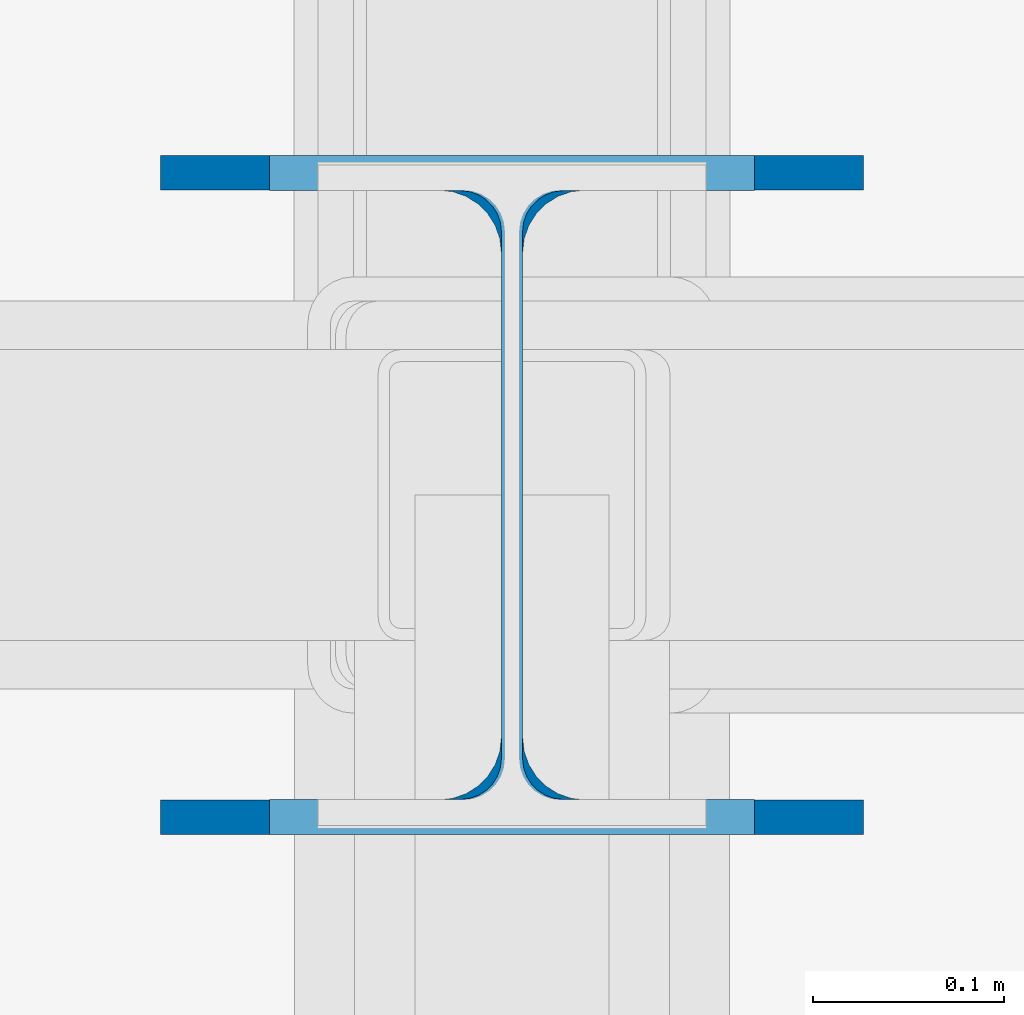
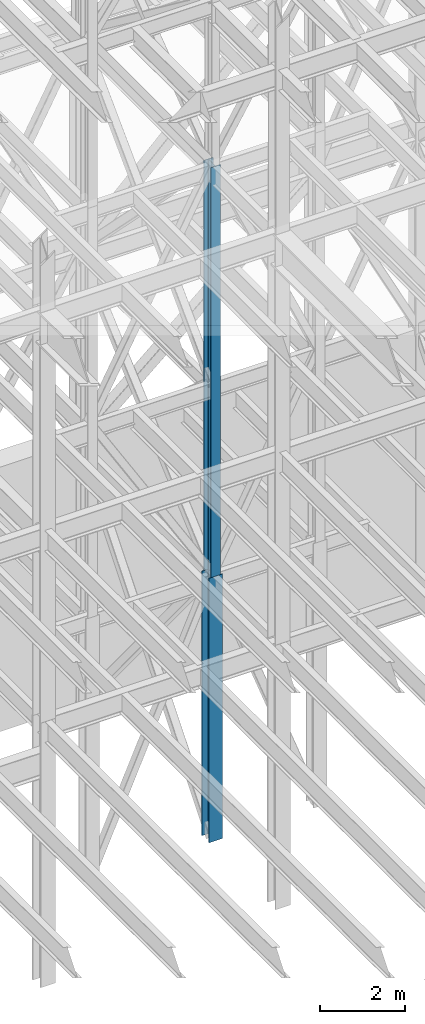
# One storey, part 45 of 150: 2 columns.
"""IFC2X3 building model written with IfcOpenShell, lengths in millimetres."""

from ifc_helpers import new_model, si_unit, frame, origin_with_axes, origin_2d_with_axis, place, context, subcontext, project, spatial, i_section, extrude, material, type_object, element, save


model = new_model("IFC2X3")

# Units and contexts
model_context = context("Model", 3, precision=1e-05, world=origin_with_axes())
body_context = subcontext(model_context, "Body", "Model", "MODEL_VIEW")
ifc_project = project(units=[si_unit("LENGTHUNIT", "METRE", prefix="MILLI"), si_unit("AREAUNIT", "SQUARE_METRE"), si_unit("VOLUMEUNIT", "CUBIC_METRE"), si_unit("MASSUNIT", "GRAM", prefix="KILO"), si_unit("TIMEUNIT", "SECOND"), si_unit("PLANEANGLEUNIT", "RADIAN"), si_unit("SOLIDANGLEUNIT", "STERADIAN"), si_unit("THERMODYNAMICTEMPERATUREUNIT", "DEGREE_CELSIUS"), si_unit("LUMINOUSINTENSITYUNIT", "LUMEN")], contexts=[model_context])

# Site, building, storey
site_placement = place(None, origin_with_axes())
site = spatial("IfcSite", under=ifc_project, at=site_placement, CompositionType="ELEMENT")
building_placement = place(site_placement, origin_with_axes())
building = spatial("IfcBuilding", under=site, at=building_placement, Name="Undefined", CompositionType="ELEMENT")
storey_placement = place(building_placement, origin_with_axes())
storey = spatial("IfcBuildingStorey", under=building, at=storey_placement, Name="Undefined", CompositionType="ELEMENT", Elevation=0.0)

# Columns
ifc_material = material(Name="STEEL/A992")
column_type_1 = type_object("IfcColumnType", Name="W14X68", PredefinedType="NOTDEFINED")
column_1_placement = place(storey_placement, frame((56591.2, 25628.6, 23774.4), z_axis=(0.0, 0.0, 1.0), x_axis=(1.0, 0.0, 0.0)))
element("IfcColumn", 1, at=column_1_placement, inside=storey, type_object=column_type_1, material=ifc_material, Name="COLUMN", ObjectType="W14X68", context=body_context, shape_type="SweptSolid", body=[
    extrude(i_section(OverallWidth=254.0, OverallDepth=355.6, WebThickness=11.1125, FlangeThickness=18.288, FilletRadius=21.3994, at=origin_2d_with_axis()), frame((0.0, 0.0, 11811.0), z_axis=(0.0, 0.0, -1.0), x_axis=(-1.0, 0.0, 0.0)), (0.0, 0.0, 1.0), 11811.0),
])
column_type_2 = type_object("IfcColumnType", Name="W14X90", PredefinedType="NOTDEFINED")
column_2_placement = place(storey_placement, frame((56591.2, 25628.6, 16154.4), z_axis=(0.0, 0.0, 1.0), x_axis=(1.0, 0.0, 0.0)))
element("IfcColumn", 2, at=column_2_placement, inside=storey, type_object=column_type_2, material=ifc_material, Name="COLUMN", ObjectType="W14X90", context=body_context, shape_type="SweptSolid", body=[
    extrude(i_section(OverallWidth=368.3, OverallDepth=355.6, WebThickness=11.1125, FlangeThickness=18.034, FilletRadius=32.7659, at=origin_2d_with_axis()), frame((0.0, 0.0, 7620.0), z_axis=(0.0, 0.0, -1.0), x_axis=(-1.0, 0.0, 0.0)), (0.0, 0.0, 1.0), 7620.0),
])

save(model, "model.ifc")
